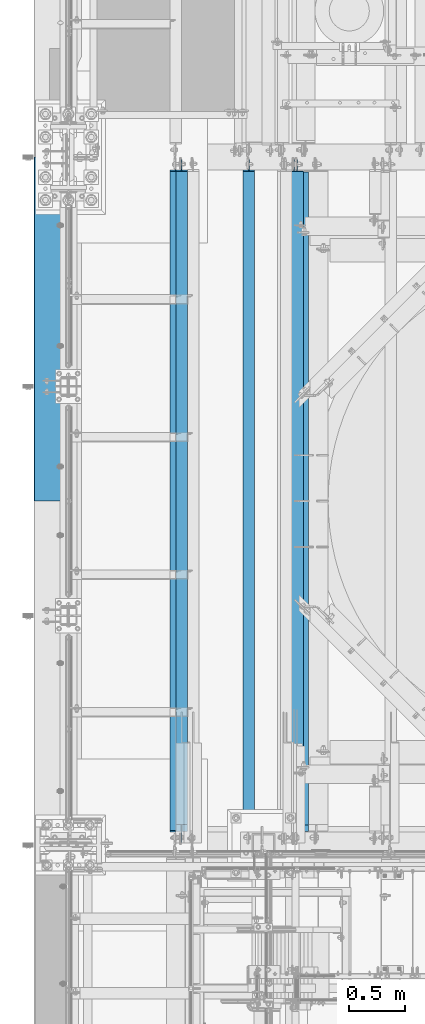
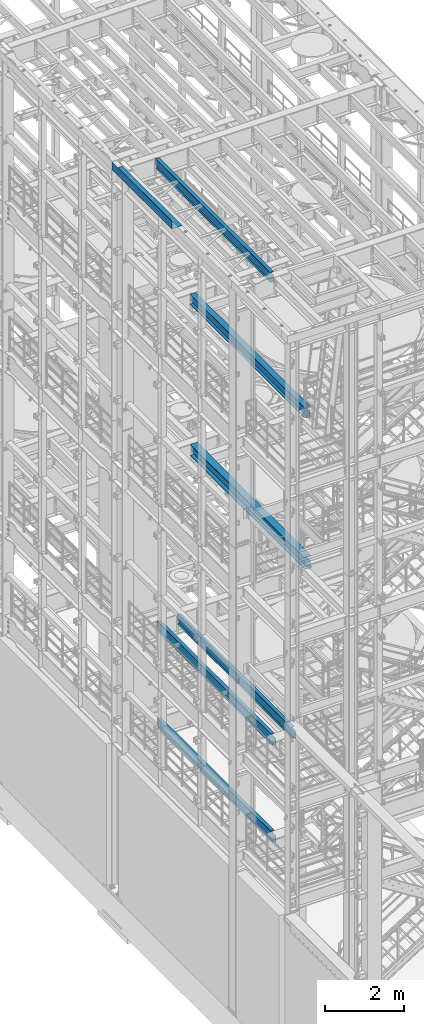
# One storey, part 1008 of 1876: 7 beams, 7 elements without a shape of their own.
"""IFC2X3 building model written with IfcOpenShell, lengths in millimetres."""

from ifc_helpers import new_model, si_unit, frame, origin_with_axes, place, context, subcontext, project, spatial, faceted_brep, material, type_object, element, aggregate, save


model = new_model("IFC2X3")

# Units and contexts
model_context = context("Model", 3, precision=1e-05, world=origin_with_axes())
body_context = subcontext(model_context, "Body", "Model", "MODEL_VIEW")
ifc_project = project(units=[si_unit("LENGTHUNIT", "METRE", prefix="MILLI"), si_unit("AREAUNIT", "SQUARE_METRE"), si_unit("VOLUMEUNIT", "CUBIC_METRE"), si_unit("MASSUNIT", "GRAM", prefix="KILO"), si_unit("TIMEUNIT", "SECOND"), si_unit("PLANEANGLEUNIT", "RADIAN"), si_unit("SOLIDANGLEUNIT", "STERADIAN"), si_unit("THERMODYNAMICTEMPERATUREUNIT", "DEGREE_CELSIUS"), si_unit("LUMINOUSINTENSITYUNIT", "LUMEN")], contexts=[model_context])

# Site, building, storey
site_placement = place(None, origin_with_axes())
site = spatial("IfcSite", under=ifc_project, at=site_placement, CompositionType="ELEMENT")
building_placement = place(site_placement, origin_with_axes())
building = spatial("IfcBuilding", under=site, at=building_placement, Name="Undefined", CompositionType="ELEMENT")
storey_placement = place(building_placement, origin_with_axes())
storey = spatial("IfcBuildingStorey", under=building, at=storey_placement, Name="Undefined", CompositionType="ELEMENT", Elevation=0.0)

# Assembly, beam
assembly_1_placement = place(storey_placement, origin_with_axes())
assembly_1 = element("IfcElementAssembly", 1, at=assembly_1_placement, inside=storey, Name="BEAM", AssemblyPlace="NOTDEFINED", PredefinedType="RIGID_FRAME")
ifc_material_1 = material(Name="STEEL/A992")
beam_type_1 = type_object("IfcBeamType", Name="W12X16", PredefinedType="NOTDEFINED")
beam_1_placement = place(assembly_1_placement, frame((1600.2, -4572.0, 8001.0), z_axis=(0.0, 0.0, 1.0), x_axis=(0.0, 1.0, 0.0)))
beam_1 = element("IfcBeam", 2, at=beam_1_placement, type_object=beam_type_1, material=ifc_material_1, Name="BEAM", ObjectType="W12X16", context=body_context, shape_type="Brep", body=[
    faceted_brep([(23.0187500000002, -3.17499999999995, -127.0), (23.0187500000002, 3.17499999999995, -127.0), (105.568750190733, 3.17500002409543, -127.0), (105.568750190733, -3.17499999999995, -127.0), (110.428829708779, 3.17500002425345, -127.966729922588), (110.428829708779, -3.17499999999995, -127.966729922588), (114.549006176932, 3.17500002470138, -130.719743823066), (114.549006176932, -3.17499999999995, -130.719743823066), (117.302020077411, 3.17500002537099, -134.83992029122), (117.302020077411, -3.17499999999995, -134.83992029122), (118.268749999998, -3.17499999999995, -139.699999809265), (118.268749999998, 3.17500002616043, -139.699999809265), (118.268749999998, 3.17500008940715, -146.05), (118.268749999998, 3.17500009536752, -152.4), (118.268749999998, -50.8, -152.4), (118.268749999998, -50.8, -146.05), (118.268749999998, -3.17499999999995, -146.05), (5980.90625, 50.8, -146.05), (5980.90625, 50.8, -152.4), (124.61875, 50.8, -152.4), (124.61875, 50.8, -146.05), (124.61875, 3.17500009536752, -152.4), (124.61875, 3.17500009536752, -146.05), (5980.90625, 3.17499999999995, -146.05), (5968.20625, 50.8, 146.05), (5968.20625, 3.17499999999995, 146.05), (181.768749999998, 3.17499999999995, 146.05), (181.768749999998, 50.8, 146.05), (169.068750190733, -3.17499999999995, 101.6), (169.068750190733, 3.17499998798007, 101.6), (23.0187500000002, 3.17499999999995, 101.6), (23.0187500000002, -3.17499999999995, 101.6), (173.928829708779, -3.17499999999995, 102.566729922588), (173.928829708779, 3.17499998782432, 102.566729922588), (178.049006176932, -3.17499999999995, 105.319743823066), (178.049006176932, 3.17499998738072, 105.319743823066), (180.802020077411, -3.17499999999995, 109.43992029122), (180.802020077411, 3.17499998671678, 109.43992029122), (181.768749999998, -3.17499999999995, 114.299999809266), (181.768749999998, 3.17499998593348, 114.299999809266), (5968.20625, -50.8, 152.4), (5968.20625, 50.8, 152.4), (181.768749999998, 50.8, 152.4), (181.768749999998, -50.8, 152.4), (5968.20625, -50.8, 146.05), (181.768749999998, -50.8, 146.05), (5968.20625, -3.17499999999995, 146.05), (181.768749999998, -3.17499999999995, 146.05), (5968.20625, -3.17499999999995, 126.999999809264), (5968.20625, 3.17499999999995, 126.999999809264), (5969.17297992259, -3.17499999999995, 122.139920291219), (5969.17297992259, 3.17499999999995, 122.139920291219), (5971.92599382307, -3.17499999999995, 118.019743823065), (5971.92599382307, 3.17499999999995, 118.019743823065), (5976.04617029122, -3.17499999999995, 115.266729922587), (5976.04617029122, 3.17499999999995, 115.266729922587), (5980.90624980927, -3.17499999999995, 114.299999999999), (5980.90624980927, 3.17499999999995, 114.299999999999), (6076.15625, -3.17499999999995, 114.299999999999), (6076.15625, 3.17499999999995, 114.299999999999), (6076.15625, -3.17499999999995, -126.999999999996), (6076.15625, 3.17499999999995, -126.999999999996), (5993.60624980927, -3.17499999999995, -127.000000000001), (5993.60624980927, 3.17499999999995, -127.000000000001), (5988.74617029122, -3.17499999999995, -127.966729922588), (5988.74617029122, 3.17499999999995, -127.966729922588), (5984.62599382307, -3.17499999999995, -130.719743823067), (5984.62599382307, 3.17499999999995, -130.719743823067), (5981.87297992259, -3.17499999999995, -134.839920291221), (5981.87297992259, 3.17499999999995, -134.839920291221), (5980.90625, -3.17499999999995, -139.699999809266), (5980.90625, 3.17499999999995, -139.699999809266), (5980.90625, -3.17499999999995, -146.05), (5980.90625, -50.8, -146.05), (5980.90625, -50.8, -152.4)], [[[0, 1, 2, 3]], [[3, 2, 4, 5]], [[5, 4, 6, 7]], [[7, 6, 8, 9]], [[10, 11, 12, 13, 14, 15, 16]], [[9, 8, 11, 10]], [[17, 18, 19, 20]], [[20, 19, 21, 22]], [[23, 17, 20, 22]], [[24, 25, 26, 27]], [[28, 29, 30, 31]], [[32, 33, 29, 28]], [[34, 35, 33, 32]], [[36, 37, 35, 34]], [[38, 39, 37, 36]], [[40, 41, 42, 43]], [[44, 40, 43, 45]], [[46, 44, 45, 47]], [[43, 42, 27, 26, 39, 38, 47, 45]], [[41, 24, 27, 42]], [[40, 44, 46, 48, 49, 25, 24, 41]], [[50, 51, 49, 48]], [[52, 53, 51, 50]], [[54, 55, 53, 52]], [[56, 57, 55, 54]], [[58, 59, 57, 56]], [[59, 58, 60, 61]], [[60, 62, 63, 61]], [[64, 65, 63, 62]], [[66, 67, 65, 64]], [[68, 69, 67, 66]], [[70, 71, 69, 68]], [[72, 73, 74, 18, 17, 23, 71, 70]], [[73, 72, 16, 15]], [[74, 73, 15, 14]], [[21, 19, 18, 74, 14, 13]], [[22, 21, 13, 12]], [[6, 4, 2, 1, 30, 29, 33, 35, 37, 39, 26, 25, 49, 51, 53, 55, 57, 59, 61, 63, 65, 67, 69, 71, 23, 22, 12, 11, 8]], [[31, 30, 1, 0]], [[72, 70, 68, 66, 64, 62, 60, 58, 56, 54, 52, 50, 48, 46, 47, 38, 36, 34, 32, 28, 31, 0, 3, 5, 7, 9, 10, 16]]]),
])
aggregate(assembly_1, [beam_1])

assembly_2_placement = place(storey_placement, origin_with_axes())
assembly_2 = element("IfcElementAssembly", 3, at=assembly_2_placement, inside=storey, Name="BEAM", AssemblyPlace="NOTDEFINED", PredefinedType="RIGID_FRAME")
beam_2_placement = place(assembly_2_placement, frame((1003.3, -4572.0, 8001.0), z_axis=(0.0, 0.0, 1.0), x_axis=(0.0, 1.0, 0.0)))
beam_2 = element("IfcBeam", 4, at=beam_2_placement, type_object=beam_type_1, material=ifc_material_1, Name="BEAM", ObjectType="W12X16", context=body_context, shape_type="Brep", body=[
    faceted_brep([(23.0187500000002, -3.17499999999995, -127.0), (23.0187500000002, 3.17499999999995, -127.0), (105.568750190733, 3.17500002409543, -127.0), (105.568750190733, -3.17499999999995, -127.0), (110.428829708779, 3.17500002425345, -127.966729922588), (110.428829708779, -3.17499999999995, -127.966729922588), (114.549006176932, 3.17500002470138, -130.719743823066), (114.549006176932, -3.17499999999995, -130.719743823066), (117.302020077411, 3.17500002537099, -134.83992029122), (117.302020077411, -3.17499999999995, -134.83992029122), (118.268749999998, -3.17499999999995, -139.699999809265), (118.268749999998, 3.17500002616043, -139.699999809265), (118.268749999998, 3.17500008940715, -146.05), (118.268749999998, 3.17500009536752, -152.4), (118.268749999998, -50.8, -152.4), (118.268749999998, -50.8, -146.05), (118.268749999998, -3.17499999999995, -146.05), (5980.90625, 50.8, -146.05), (5980.90625, 50.8, -152.4), (124.61875, 50.8, -152.4), (124.61875, 50.8, -146.05), (124.61875, 3.17500009536752, -152.4), (124.61875, 3.17500009536752, -146.05), (5980.90625, 3.17499999999995, -146.05), (5968.20625, 50.8, 146.05), (5968.20625, 3.17499999999995, 146.05), (181.768749999998, 3.17499999999995, 146.05), (181.768749999998, 50.8, 146.05), (169.068750190733, -3.17499999999995, 101.6), (169.068750190733, 3.17499998798007, 101.6), (23.0187500000002, 3.17499999999995, 101.6), (23.0187500000002, -3.17499999999995, 101.6), (173.928829708779, -3.17499999999995, 102.566729922588), (173.928829708779, 3.17499998782432, 102.566729922588), (178.049006176932, -3.17499999999995, 105.319743823066), (178.049006176932, 3.17499998738072, 105.319743823066), (180.802020077411, -3.17499999999995, 109.43992029122), (180.802020077411, 3.17499998671678, 109.43992029122), (181.768749999998, -3.17499999999995, 114.299999809266), (181.768749999998, 3.17499998593348, 114.299999809266), (5968.20625, -50.8, 152.4), (5968.20625, 50.8, 152.4), (181.768749999998, 50.8, 152.4), (181.768749999998, -50.8, 152.4), (5968.20625, -50.8, 146.05), (181.768749999998, -50.8, 146.05), (5968.20625, -3.17499999999995, 146.05), (181.768749999998, -3.17499999999995, 146.05), (5968.20625, -3.17499999999995, 126.999999809264), (5968.20625, 3.17499999999995, 126.999999809264), (5969.17297992259, -3.17499999999995, 122.139920291219), (5969.17297992259, 3.17499999999995, 122.139920291219), (5971.92599382307, -3.17499999999995, 118.019743823065), (5971.92599382307, 3.17499999999995, 118.019743823065), (5976.04617029122, -3.17499999999995, 115.266729922587), (5976.04617029122, 3.17499999999995, 115.266729922587), (5980.90624980927, -3.17499999999995, 114.299999999999), (5980.90624980927, 3.17499999999995, 114.299999999999), (6076.15625, -3.17499999999995, 114.299999999999), (6076.15625, 3.17499999999995, 114.299999999999), (6076.15625, -3.17499999999995, -126.999999999996), (6076.15625, 3.17499999999995, -126.999999999996), (5993.60624980927, -3.17499999999995, -127.000000000001), (5993.60624980927, 3.17499999999995, -127.000000000001), (5988.74617029122, -3.17499999999995, -127.966729922588), (5988.74617029122, 3.17499999999995, -127.966729922588), (5984.62599382307, -3.17499999999995, -130.719743823067), (5984.62599382307, 3.17499999999995, -130.719743823067), (5981.87297992259, -3.17499999999995, -134.839920291221), (5981.87297992259, 3.17499999999995, -134.839920291221), (5980.90625, -3.17499999999995, -139.699999809266), (5980.90625, 3.17499999999995, -139.699999809266), (5980.90625, -3.17499999999995, -146.05), (5980.90625, -50.8, -146.05), (5980.90625, -50.8, -152.4)], [[[0, 1, 2, 3]], [[3, 2, 4, 5]], [[5, 4, 6, 7]], [[7, 6, 8, 9]], [[10, 11, 12, 13, 14, 15, 16]], [[9, 8, 11, 10]], [[17, 18, 19, 20]], [[20, 19, 21, 22]], [[23, 17, 20, 22]], [[24, 25, 26, 27]], [[28, 29, 30, 31]], [[32, 33, 29, 28]], [[34, 35, 33, 32]], [[36, 37, 35, 34]], [[38, 39, 37, 36]], [[40, 41, 42, 43]], [[44, 40, 43, 45]], [[46, 44, 45, 47]], [[43, 42, 27, 26, 39, 38, 47, 45]], [[41, 24, 27, 42]], [[40, 44, 46, 48, 49, 25, 24, 41]], [[50, 51, 49, 48]], [[52, 53, 51, 50]], [[54, 55, 53, 52]], [[56, 57, 55, 54]], [[58, 59, 57, 56]], [[59, 58, 60, 61]], [[60, 62, 63, 61]], [[64, 65, 63, 62]], [[66, 67, 65, 64]], [[68, 69, 67, 66]], [[70, 71, 69, 68]], [[72, 73, 74, 18, 17, 23, 71, 70]], [[73, 72, 16, 15]], [[74, 73, 15, 14]], [[21, 19, 18, 74, 14, 13]], [[22, 21, 13, 12]], [[6, 4, 2, 1, 30, 29, 33, 35, 37, 39, 26, 25, 49, 51, 53, 55, 57, 59, 61, 63, 65, 67, 69, 71, 23, 22, 12, 11, 8]], [[31, 30, 1, 0]], [[72, 70, 68, 66, 64, 62, 60, 58, 56, 54, 52, 50, 48, 46, 47, 38, 36, 34, 32, 28, 31, 0, 3, 5, 7, 9, 10, 16]]]),
])
aggregate(assembly_2, [beam_2])

assembly_3_placement = place(storey_placement, origin_with_axes())
assembly_3 = element("IfcElementAssembly", 5, at=assembly_3_placement, inside=storey, Name="BEAM", AssemblyPlace="NOTDEFINED", PredefinedType="RIGID_FRAME")
beam_3_placement = place(assembly_3_placement, frame((952.5, -4572.0, 22402.8), z_axis=(0.0, 0.0, 1.0), x_axis=(0.0, 1.0, 0.0)))
beam_3 = element("IfcBeam", 6, at=beam_3_placement, type_object=beam_type_1, material=ifc_material_1, Name="BEAM", ObjectType="W12X16", context=body_context, shape_type="Brep", body=[
    faceted_brep([(19.84375, -3.17499999999995, -126.999999999996), (19.84375, 3.17499999999995, -126.999999999996), (102.393750190735, 3.17500000000018, -127.000000000001), (102.393750190735, -3.17500000000018, -127.000000000001), (107.25382970878, 3.17500000000018, -127.966729922588), (107.25382970878, -3.17500000000018, -127.966729922588), (111.374006176934, 3.17500000000018, -130.719743823067), (111.374006176934, -3.17500000000018, -130.719743823067), (114.127020077412, 3.17500000000018, -134.839920291221), (114.127020077412, -3.17500000000018, -134.839920291221), (115.09375, -3.17500000000018, -139.699999809266), (115.09375, 3.17500000000018, -139.699999809266), (115.09375, 3.17500000000018, -146.05), (115.09375, 50.8000000000002, -146.05), (115.09375, 50.8000000000002, -152.4), (115.09375, -50.8000000000002, -152.4), (115.09375, -50.8000000000002, -146.05), (115.09375, -3.17500000000018, -146.05), (127.79375, 3.17500000000018, 146.05), (127.79375, 50.8000000000002, 146.05), (5968.20625, 50.8, 146.05), (5968.20625, 3.17499999999995, 146.05), (115.093750190735, -3.17500000000018, 114.299999999999), (115.093750190735, 3.17500000000018, 114.299999999999), (19.84375, 3.17500000000018, 114.299999999999), (19.84375, -3.17500000000018, 114.299999999999), (119.95382970878, -3.17500000000018, 115.266729922587), (119.95382970878, 3.17500000000018, 115.266729922587), (124.074006176934, -3.17500000000018, 118.019743823065), (124.074006176934, 3.17500000000018, 118.019743823065), (126.827020077412, -3.17500000000018, 122.139920291219), (126.827020077412, 3.17500000000018, 122.139920291219), (127.79375, -3.17500000000018, 126.999999809264), (127.79375, 3.17500000000018, 126.999999809264), (127.79375, 50.8000000000002, 152.4), (127.79375, -50.8000000000002, 152.4), (5968.20625, -50.8, 152.4), (5968.20625, 50.8, 152.4), (127.79375, -50.8000000000002, 146.05), (5968.20625, -50.8, 146.05), (127.79375, -3.17500000000018, 146.05), (5968.20625, -3.17499999999995, 146.05), (5968.20625, -3.17499999999995, 126.999999809264), (5968.20625, 3.17499999999995, 126.999999809264), (5969.17297992259, -3.17499999999995, 122.139920291219), (5969.17297992259, 3.17499999999995, 122.139920291219), (5971.92599382307, -3.17499999999995, 118.019743823065), (5971.92599382307, 3.17499999999995, 118.019743823065), (5976.04617029122, -3.17499999999995, 115.266729922587), (5976.04617029122, 3.17499999999995, 115.266729922587), (5980.90624980927, -3.17499999999995, 114.299999999999), (5980.90624980927, 3.17499999999995, 114.299999999999), (6076.15625, -3.17499999999995, 114.299999999999), (6076.15625, 3.17499999999995, 114.299999999999), (6076.15625, -3.17499999999995, -126.999999999996), (6076.15625, 3.17499999999995, -126.999999999996), (5993.60624980927, -3.17499999999995, -127.000000000001), (5993.60624980927, 3.17499999999995, -127.000000000001), (5988.74617029122, -3.17499999999995, -127.966729922588), (5988.74617029122, 3.17499999999995, -127.966729922588), (5984.62599382307, -3.17499999999995, -130.719743823067), (5984.62599382307, 3.17499999999995, -130.719743823067), (5981.87297992259, -3.17499999999995, -134.839920291221), (5981.87297992259, 3.17499999999995, -134.839920291221), (5980.90625, -3.17499999999995, -139.699999809266), (5980.90625, 3.17499999999995, -139.699999809266), (5980.90625, -3.17499999999995, -146.05), (5980.90625, -50.8, -146.05), (5980.90625, -50.8, -152.4), (5980.90625, 50.8, -152.4), (5980.90625, 50.8, -146.05), (5980.90625, 3.17499999999995, -146.05)], [[[0, 1, 2, 3]], [[3, 2, 4, 5]], [[5, 4, 6, 7]], [[7, 6, 8, 9]], [[10, 11, 12, 13, 14, 15, 16, 17]], [[9, 8, 11, 10]], [[18, 19, 20, 21]], [[22, 23, 24, 25]], [[26, 27, 23, 22]], [[28, 29, 27, 26]], [[30, 31, 29, 28]], [[32, 33, 31, 30]], [[34, 35, 36, 37]], [[35, 38, 39, 36]], [[38, 40, 41, 39]], [[35, 34, 19, 18, 33, 32, 40, 38]], [[19, 34, 37, 20]], [[36, 39, 41, 42, 43, 21, 20, 37]], [[44, 45, 43, 42]], [[46, 47, 45, 44]], [[48, 49, 47, 46]], [[50, 51, 49, 48]], [[52, 53, 51, 50]], [[53, 52, 54, 55]], [[54, 56, 57, 55]], [[58, 59, 57, 56]], [[60, 61, 59, 58]], [[62, 63, 61, 60]], [[64, 65, 63, 62]], [[66, 67, 68, 69, 70, 71, 65, 64]], [[17, 16, 67, 66]], [[16, 15, 68, 67]], [[15, 14, 69, 68]], [[14, 13, 70, 69]], [[13, 12, 71, 70]], [[59, 61, 63, 65, 71, 12, 11, 8, 6, 4, 2, 1, 24, 23, 27, 29, 31, 33, 18, 21, 43, 45, 47, 49, 51, 53, 55, 57]], [[25, 24, 1, 0]], [[52, 50, 48, 46, 44, 42, 41, 40, 32, 30, 28, 26, 22, 25, 0, 3, 5, 7, 9, 10, 17, 66, 64, 62, 60, 58, 56, 54]]]),
])
aggregate(assembly_3, [beam_3])

assembly_4_placement = place(storey_placement, origin_with_axes())
assembly_4 = element("IfcElementAssembly", 7, at=assembly_4_placement, inside=storey, Name="BEAM", AssemblyPlace="NOTDEFINED", PredefinedType="RIGID_FRAME")
beam_4_placement = place(assembly_4_placement, frame((1003.3, -4572.0, 4978.4), z_axis=(0.0, 0.0, 1.0), x_axis=(0.0, 1.0, 0.0)))
beam_4 = element("IfcBeam", 8, at=beam_4_placement, type_object=beam_type_1, material=ifc_material_1, Name="BEAM", ObjectType="W12X16", context=body_context, shape_type="Brep", body=[
    faceted_brep([(23.0187500000002, -3.17499999999995, -127.0), (23.0187500000002, 3.17499999999995, -127.0), (105.568750190733, 3.17500002409543, -127.0), (105.568750190733, -3.17499999999995, -127.0), (110.428829708779, 3.17500002425345, -127.966729922588), (110.428829708779, -3.17499999999995, -127.966729922588), (114.549006176932, 3.17500002470138, -130.719743823066), (114.549006176932, -3.17499999999995, -130.719743823066), (117.302020077411, 3.17500002537099, -134.83992029122), (117.302020077411, -3.17499999999995, -134.83992029122), (118.268749999998, -3.17499999999995, -139.699999809265), (118.268749999998, 3.17500002616043, -139.699999809265), (118.268749999998, 3.17500008940715, -146.05), (118.268749999998, 50.8000000000002, -146.05), (118.268749999998, 50.8000000000002, -152.4), (118.268749999998, -50.8, -152.4), (118.268749999998, -50.8, -146.05), (118.268749999998, -3.17499999999995, -146.05), (5968.20625, 50.8, 146.05), (5968.20625, 3.17499999999995, 146.05), (181.768749999998, 3.17499999999995, 146.05), (181.768749999998, 50.8, 146.05), (169.068750190733, -3.17499999999995, 101.6), (169.068750190733, 3.17499998798007, 101.6), (23.0187500000002, 3.17499999999995, 101.6), (23.0187500000002, -3.17499999999995, 101.6), (173.928829708779, -3.17499999999995, 102.566729922588), (173.928829708779, 3.17499998782432, 102.566729922588), (178.049006176932, -3.17499999999995, 105.319743823066), (178.049006176932, 3.17499998738072, 105.319743823066), (180.802020077411, -3.17499999999995, 109.43992029122), (180.802020077411, 3.17499998671678, 109.43992029122), (181.768749999998, -3.17499999999995, 114.299999809266), (181.768749999998, 3.17499998593348, 114.299999809266), (5968.20625, -50.8, 152.4), (5968.20625, 50.8, 152.4), (181.768749999998, 50.8, 152.4), (181.768749999998, -50.8, 152.4), (5968.20625, -50.8, 146.05), (181.768749999998, -50.8, 146.05), (5968.20625, -3.17499999999995, 146.05), (181.768749999998, -3.17499999999995, 146.05), (5968.20625, -3.17499999999995, 126.999999809264), (5968.20625, 3.17499999999995, 126.999999809264), (5969.17297992259, -3.17499999999995, 122.139920291219), (5969.17297992259, 3.17499999999995, 122.139920291219), (5971.92599382307, -3.17499999999995, 118.019743823065), (5971.92599382307, 3.17499999999995, 118.019743823065), (5976.04617029122, -3.17499999999995, 115.266729922587), (5976.04617029122, 3.17499999999995, 115.266729922587), (5980.90624980927, -3.17499999999995, 114.299999999999), (5980.90624980927, 3.17499999999995, 114.299999999999), (6076.15625, -3.17499999999995, 114.299999999999), (6076.15625, 3.17499999999995, 114.299999999999), (6076.15625, -3.17499999999995, -126.999999999996), (6076.15625, 3.17499999999995, -126.999999999996), (5993.60624980927, -3.17499999999995, -127.000000000001), (5993.60624980927, 3.17499999999995, -127.000000000001), (5988.74617029122, -3.17499999999995, -127.966729922588), (5988.74617029122, 3.17499999999995, -127.966729922588), (5984.62599382307, -3.17499999999995, -130.719743823067), (5984.62599382307, 3.17499999999995, -130.719743823067), (5981.87297992259, -3.17499999999995, -134.839920291221), (5981.87297992259, 3.17499999999995, -134.839920291221), (5980.90625, -3.17499999999995, -139.699999809266), (5980.90625, 3.17499999999995, -139.699999809266), (5980.90625, -3.17499999999995, -146.05), (5980.90625, -50.8, -146.05), (5980.90625, -50.8, -152.4), (5980.90625, 50.8, -152.4), (5980.90625, 50.8, -146.05), (5980.90625, 3.17499999999995, -146.05)], [[[0, 1, 2, 3]], [[3, 2, 4, 5]], [[5, 4, 6, 7]], [[7, 6, 8, 9]], [[10, 11, 12, 13, 14, 15, 16, 17]], [[9, 8, 11, 10]], [[18, 19, 20, 21]], [[22, 23, 24, 25]], [[26, 27, 23, 22]], [[28, 29, 27, 26]], [[30, 31, 29, 28]], [[32, 33, 31, 30]], [[34, 35, 36, 37]], [[38, 34, 37, 39]], [[40, 38, 39, 41]], [[37, 36, 21, 20, 33, 32, 41, 39]], [[35, 18, 21, 36]], [[34, 38, 40, 42, 43, 19, 18, 35]], [[44, 45, 43, 42]], [[46, 47, 45, 44]], [[48, 49, 47, 46]], [[50, 51, 49, 48]], [[52, 53, 51, 50]], [[53, 52, 54, 55]], [[54, 56, 57, 55]], [[58, 59, 57, 56]], [[60, 61, 59, 58]], [[62, 63, 61, 60]], [[64, 65, 63, 62]], [[66, 67, 68, 69, 70, 71, 65, 64]], [[67, 66, 17, 16]], [[68, 67, 16, 15]], [[69, 68, 15, 14]], [[70, 69, 14, 13]], [[71, 70, 13, 12]], [[6, 4, 2, 1, 24, 23, 27, 29, 31, 33, 20, 19, 43, 45, 47, 49, 51, 53, 55, 57, 59, 61, 63, 65, 71, 12, 11, 8]], [[25, 24, 1, 0]], [[66, 64, 62, 60, 58, 56, 54, 52, 50, 48, 46, 44, 42, 40, 41, 32, 30, 28, 26, 22, 25, 0, 3, 5, 7, 9, 10, 17]]]),
])
aggregate(assembly_4, [beam_4])

assembly_5_placement = place(storey_placement, origin_with_axes())
assembly_5 = element("IfcElementAssembly", 9, at=assembly_5_placement, inside=storey, Name="BENT PLATE", AssemblyPlace="NOTDEFINED", PredefinedType="RIGID_FRAME")
ifc_material_2 = material(Name="STEEL/A36")
beam_type_2 = type_object("IfcBeamType", PredefinedType="NOTDEFINED")
beam_5_placement = place(assembly_5_placement, frame((2.28578142867657e-05, 0.0, 22558.3750000001), z_axis=(0.0, 1.0, 0.0), x_axis=(-0.999999999968684, 0.0, -7.91400000071008e-06)))
beam_5 = element("IfcBeam", 10, at=beam_5_placement, type_object=beam_type_2, material=ifc_material_2, Name="BENT PLATE", context=body_context, shape_type="Brep", body=[
    faceted_brep([(9.877112461254e-10, -3.17499999999563, -1524.0), (9.877112461254e-10, -3.17499999999563, 1524.0), (-9.88620740827173e-10, 3.17500000000291, 1524.0), (-9.88620740827173e-10, 3.17500000000291, -1524.0), (298.449951181141, 3.17499990714714, 1524.0), (298.449951181141, 3.17499990714714, -1524.0), (304.799984389467, -3.1750000948341, -1524.0), (304.799984389467, -3.1750000948341, 1524.0), (298.448604036157, 236.934945778325, 1524.0), (298.448604036646, 236.934945778212, -1524.0), (304.798604036052, 236.934982372997, 1524.0), (304.798604036541, 236.934982372881, -1524.0)], [[[0, 1, 2, 3]], [[3, 2, 4, 5]], [[1, 0, 6, 7]], [[5, 4, 8, 9]], [[4, 2, 1, 7, 10, 8]], [[7, 6, 11, 10]], [[6, 0, 3, 5, 9, 11]], [[10, 11, 9, 8]]]),
])
aggregate(assembly_5, [beam_5])

assembly_6_placement = place(storey_placement, origin_with_axes())
assembly_6 = element("IfcElementAssembly", 11, at=assembly_6_placement, inside=storey, Name="BEAM", AssemblyPlace="NOTDEFINED", PredefinedType="RIGID_FRAME")
beam_type_3 = type_object("IfcBeamType", Name="W12X30", PredefinedType="NOTDEFINED")
beam_6_placement = place(assembly_6_placement, frame((2000.24988645128, -4571.99999911051, 17826.0375), z_axis=(0.0, 0.0, 1.0), x_axis=(0.0, 1.0, 0.0)))
beam_6 = element("IfcBeam", 12, at=beam_6_placement, type_object=beam_type_3, material=ifc_material_1, Name="BEAM", ObjectType="W12X30", context=body_context, shape_type="Brep", body=[
    faceted_brep([(19.8437500000002, -3.17500000000018, -131.762499999993), (19.8437500000002, 3.17500000000018, -131.762499999993), (108.74374930124, 3.17499999999995, -131.762499999997), (108.74374930124, -3.17499999999995, -131.762499999997), (113.603828819286, 3.17499999999995, -132.729229922585), (113.603828819286, -3.17499999999995, -132.729229922585), (117.724005287439, 3.17499999999995, -135.482243823062), (117.724005287439, -3.17499999999995, -135.482243823062), (120.477019187918, 3.17499999999995, -139.602420291216), (120.477019187918, -3.17499999999995, -139.602420291216), (121.443749110505, -3.17499999999995, -144.462499809262), (121.443749110505, 3.17499999999995, -144.462499809262), (121.44375, 3.17500000000018, -146.049999999999), (121.443749110505, 82.55, -146.049999999999), (121.443749110505, 82.55, -157.162499999999), (121.443749110505, -82.55, -157.162499999999), (121.443749110505, -82.55, -146.049999999999), (121.44375, -3.17500000000018, -146.049999999999), (5968.20624911051, 82.55, 146.049999999999), (5968.20625, 3.17499999999995, 146.05), (127.79375, 3.17500000000018, 146.05), (127.793782276814, 82.5500000000102, 146.05), (115.09374930124, -3.17499999999995, 119.062500000004), (115.09374930124, 3.17499999999995, 119.062500000004), (19.8437491105051, 3.17499999999995, 119.062500000004), (19.8437491105051, -3.17499999999995, 119.062500000004), (119.953828819285, -3.17499999999995, 120.029229922591), (119.953828819285, 3.17499999999995, 120.029229922591), (124.074005287439, -3.17499999999995, 122.782243823069), (124.074005287439, 3.17499999999995, 122.782243823069), (126.827019187917, -3.17499999999995, 126.902420291222), (126.827019187917, 3.17499999999995, 126.902420291222), (127.793749110505, -3.17499999999995, 131.762499809269), (127.793749110505, 3.17499999999995, 131.762499809269), (5968.20624911051, -82.55, 157.162499999999), (5968.20624911051, 82.55, 157.162499999999), (127.793749110505, 82.55, 157.162499999999), (127.793749110505, -82.55, 157.162499999999), (5968.20624911051, -82.55, 146.049999999999), (127.793782276821, -82.5500000000029, 146.05), (5968.20625, -3.17499999999995, 146.05), (127.79375, -3.17500000000018, 146.05), (5968.20624911051, -3.17499999999995, 131.762499809269), (5968.20624911051, 3.17499999999995, 131.762499809269), (5969.17297903309, -3.17499999999995, 126.902420291222), (5969.17297903309, 3.17499999999995, 126.902420291222), (5971.92599293357, -3.17499999999995, 122.782243823069), (5971.92599293357, 3.17499999999995, 122.782243823069), (5976.04616940172, -3.17499999999995, 120.029229922591), (5976.04616940172, 3.17499999999995, 120.029229922591), (5980.90624891977, -3.17499999999995, 119.062500000004), (5980.90624891977, 3.17499999999995, 119.062500000004), (6076.15624911051, -3.17499999999995, 119.062500000004), (6076.15624911051, 3.17499999999995, 119.062500000004), (6076.15625, -3.17500000000018, -131.762499999993), (6076.15625, 3.17500000000018, -131.762499999993), (5987.25624891977, -3.17499999999995, -131.762499999997), (5987.25624891977, 3.17499999999995, -131.762499999997), (5982.39616940173, -3.17499999999995, -132.729229922585), (5982.39616940173, 3.17499999999995, -132.729229922585), (5978.27599293357, -3.17499999999995, -135.482243823062), (5978.27599293357, 3.17499999999995, -135.482243823062), (5975.52297903309, -3.17499999999995, -139.602420291216), (5975.52297903309, 3.17499999999995, -139.602420291216), (5974.55624911051, -3.17499999999995, -144.462499809262), (5974.55624911051, 3.17499999999995, -144.462499809262), (5974.55624911051, -3.17499999999995, -146.049999999999), (5974.55624911051, -82.55, -146.049999999999), (5974.55624911051, -82.55, -157.162499999999), (5974.55624911051, 82.55, -157.162499999999), (5974.55624911051, 82.55, -146.049999999999), (5974.55624911051, 3.17499999999995, -146.049999999999)], [[[0, 1, 2, 3]], [[3, 2, 4, 5]], [[5, 4, 6, 7]], [[7, 6, 8, 9]], [[10, 11, 12, 13, 14, 15, 16, 17]], [[9, 8, 11, 10]], [[18, 19, 20, 21]], [[22, 23, 24, 25]], [[26, 27, 23, 22]], [[28, 29, 27, 26]], [[30, 31, 29, 28]], [[32, 33, 31, 30]], [[34, 35, 36, 37]], [[38, 34, 37, 39]], [[40, 38, 39, 41]], [[37, 36, 21, 20, 33, 32, 41, 39]], [[35, 18, 21, 36]], [[34, 38, 40, 42, 43, 19, 18, 35]], [[44, 45, 43, 42]], [[46, 47, 45, 44]], [[48, 49, 47, 46]], [[50, 51, 49, 48]], [[52, 53, 51, 50]], [[53, 52, 54, 55]], [[54, 56, 57, 55]], [[58, 59, 57, 56]], [[60, 61, 59, 58]], [[62, 63, 61, 60]], [[64, 65, 63, 62]], [[66, 67, 68, 69, 70, 71, 65, 64]], [[67, 66, 17, 16]], [[68, 67, 16, 15]], [[69, 68, 15, 14]], [[70, 69, 14, 13]], [[71, 70, 13, 12]], [[6, 4, 2, 1, 24, 23, 27, 29, 31, 33, 20, 19, 43, 45, 47, 49, 51, 53, 55, 57, 59, 61, 63, 65, 71, 12, 11, 8]], [[25, 24, 1, 0]], [[66, 64, 62, 60, 58, 56, 54, 52, 50, 48, 46, 44, 42, 40, 41, 32, 30, 28, 26, 22, 25, 0, 3, 5, 7, 9, 10, 17]]]),
])
aggregate(assembly_6, [beam_6])

assembly_7_placement = place(storey_placement, origin_with_axes())
assembly_7 = element("IfcElementAssembly", 13, at=assembly_7_placement, inside=storey, Name="BEAM", AssemblyPlace="NOTDEFINED", PredefinedType="RIGID_FRAME")
beam_type_4 = type_object("IfcBeamType", Name="W14X48", PredefinedType="NOTDEFINED")
beam_7_placement = place(assembly_7_placement, frame((2025.65028087979, -4572.0, 13134.975), z_axis=(0.0, 0.0, 1.0), x_axis=(0.0, 1.0, 0.0)))
beam_7 = element("IfcBeam", 14, at=beam_7_placement, type_object=beam_type_4, material=ifc_material_1, Name="BEAM", ObjectType="W14X48", context=body_context, shape_type="Brep", body=[
    faceted_brep([(5965.03125, -3.96875, -158.75), (5965.03125, -101.6, -158.75), (5965.03125, -101.6, -174.625), (5965.03125, 101.6, -174.625), (5965.03125, 101.6, -158.75), (5965.03125, 3.96875, -158.75), (5965.03125, 3.96875, -155.574999809265), (5965.03125, -3.96875, -155.574999809265), (5965.99797992259, 3.96875, -150.714920291219), (5965.99797992259, -3.96875, -150.714920291219), (5968.75099382307, 3.96875, -146.594743823065), (5968.75099382307, -3.96875, -146.594743823065), (5972.87117029122, 3.96875, -143.841729922588), (5972.87117029122, -3.96875, -143.841729922588), (5977.73124980927, 3.96875, -142.875), (5977.73124980927, -3.96875, -142.875), (6076.15625, -3.96875, -142.875), (6076.15625, 3.96875, -142.875), (179.3875, 3.96875, 158.75), (179.3875, 101.6, 158.75), (5965.03125, 101.6, 158.75), (5965.03125, 3.96875, 158.75), (122.2375, -3.96875, -155.574999809263), (122.2375, 3.96875, -155.574999809263), (122.237499999999, 3.96875009536689, -158.75), (122.237499999999, 101.6, -158.75), (122.237499999999, 101.6, -174.625), (122.2375, -101.6, -174.625), (122.2375, -101.6, -158.75), (122.2375, -3.96875, -158.75), (121.270770077413, -3.96875, -150.714920291217), (121.270770077413, 3.96875, -150.714920291217), (118.517756176934, -3.96875, -146.594743823063), (118.517756176934, 3.96875, -146.594743823063), (114.397579708781, -3.96875, -143.841729922586), (114.397579708781, 3.96875, -143.841729922586), (109.537500190735, -3.96875, -142.874999999998), (109.537500190735, 3.96875, -142.874999999998), (20.6374999999998, -3.96875, -142.874999999998), (20.6374999999998, 3.96875, -142.874999999998), (20.6374999999998, -3.96875, 123.825000000003), (20.6374999999998, 3.96875, 123.825000000003), (166.687500190735, -3.96875, 123.825000000003), (166.687500190735, 3.96875, 123.825000000003), (171.54757970878, -3.96875, 124.79172992259), (171.54757970878, 3.96875, 124.79172992259), (175.667756176934, -3.96875, 127.544743823068), (175.667756176934, 3.96875, 127.544743823068), (178.420770077412, -3.96875, 131.664920291221), (178.420770077412, 3.96875, 131.664920291221), (179.3875, -3.96875, 136.524999809268), (179.3875, 3.96875, 136.524999809268), (179.3875, -101.6, 174.625), (179.3875, 101.6, 174.625), (179.3875, -3.96875, 158.75), (179.3875, -101.6, 158.75), (5965.03125, -3.96875, 158.75), (5965.03125, -101.6, 158.75), (5965.03125, -101.6, 174.625), (5965.03125, 101.6, 174.625), (5965.03125, -3.96875, 149.224999809265), (5965.03125, 3.96875, 149.224999809265), (5965.99797992259, -3.96875, 144.364920291218), (5965.99797992259, 3.96875, 144.364920291218), (5968.75099382307, -3.96875, 140.244743823065), (5968.75099382307, 3.96875, 140.244743823065), (5972.87117029122, -3.96875, 137.491729922587), (5972.87117029122, 3.96875, 137.491729922587), (5977.73124980927, -3.96875, 136.525), (5977.73124980927, 3.96875, 136.525), (6076.15625, -3.96875, 136.525), (6076.15625, 3.96875, 136.525)], [[[0, 1, 2, 3, 4, 5, 6, 7]], [[7, 6, 8, 9]], [[9, 8, 10, 11]], [[11, 10, 12, 13]], [[13, 12, 14, 15]], [[16, 15, 14, 17]], [[18, 19, 20, 21]], [[22, 23, 24, 25, 26, 27, 28, 29]], [[30, 31, 23, 22]], [[32, 33, 31, 30]], [[34, 35, 33, 32]], [[36, 37, 35, 34]], [[38, 39, 37, 36]], [[40, 41, 39, 38]], [[42, 43, 41, 40]], [[44, 45, 43, 42]], [[46, 47, 45, 44]], [[48, 49, 47, 46]], [[50, 51, 49, 48]], [[52, 53, 19, 18, 51, 50, 54, 55]], [[55, 54, 56, 57]], [[52, 55, 57, 58]], [[53, 52, 58, 59]], [[19, 53, 59, 20]], [[58, 57, 56, 60, 61, 21, 20, 59]], [[62, 63, 61, 60]], [[64, 65, 63, 62]], [[66, 67, 65, 64]], [[68, 69, 67, 66]], [[70, 71, 69, 68]], [[71, 70, 16, 17]], [[12, 10, 8, 6, 5, 24, 23, 31, 33, 35, 37, 39, 41, 43, 45, 47, 49, 51, 18, 21, 61, 63, 65, 67, 69, 71, 17, 14]], [[25, 24, 5, 4]], [[26, 25, 4, 3]], [[27, 26, 3, 2]], [[28, 27, 2, 1]], [[29, 28, 1, 0]], [[70, 68, 66, 64, 62, 60, 56, 54, 50, 48, 46, 44, 42, 40, 38, 36, 34, 32, 30, 22, 29, 0, 7, 9, 11, 13, 15, 16]]]),
])
aggregate(assembly_7, [beam_7])

save(model, "model.ifc")
